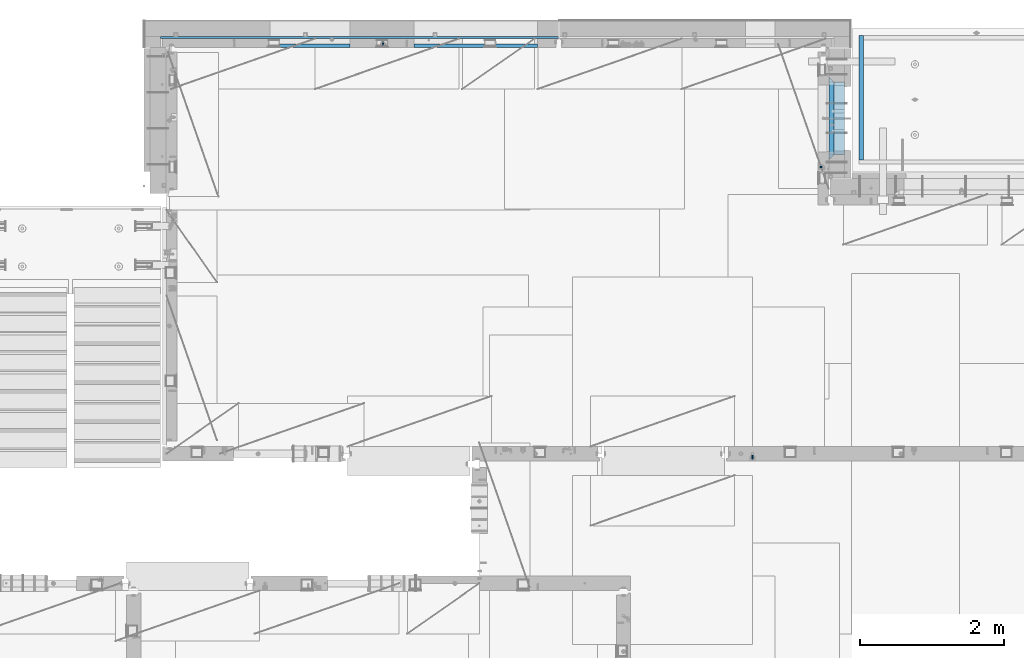
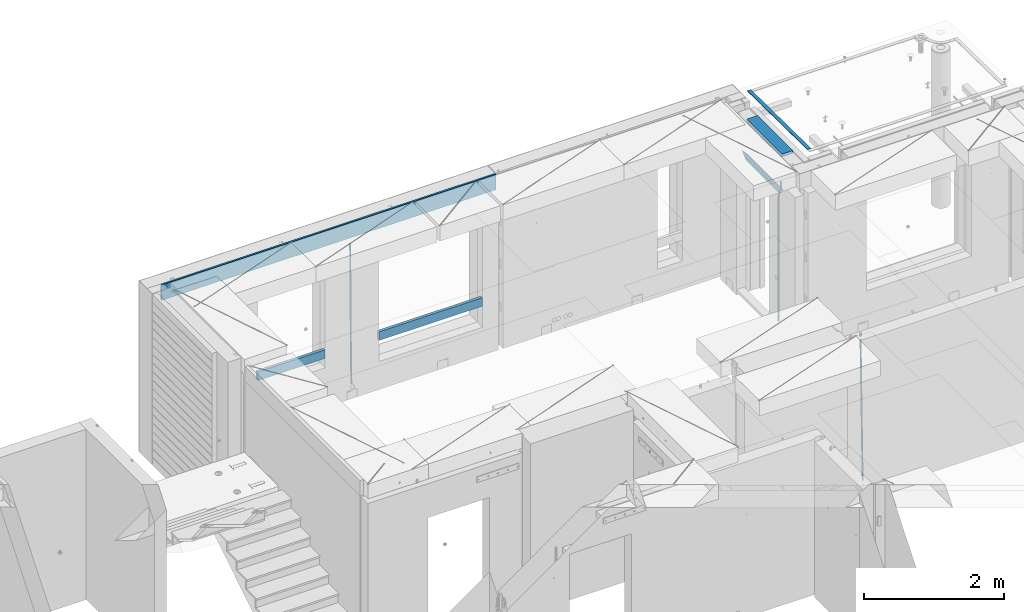
# One storey, part 120 of 334: 10 beams, 4 elements without a shape of their own.
"""IFC2X3 building model written with IfcOpenShell, lengths in millimetres."""

from ifc_helpers import new_model, si_unit, frame, origin_with_axes, place, context, subcontext, project, spatial, faceted_brep, material, type_object, element, aggregate, save


model = new_model("IFC2X3")

# Units and contexts
model_context = context("Model", 3, precision=1e-05, world=origin_with_axes())
body_context = subcontext(model_context, "Body", "Model", "MODEL_VIEW")
ifc_project = project(units=[si_unit("LENGTHUNIT", "METRE", prefix="MILLI"), si_unit("AREAUNIT", "SQUARE_METRE"), si_unit("VOLUMEUNIT", "CUBIC_METRE"), si_unit("MASSUNIT", "GRAM", prefix="KILO"), si_unit("TIMEUNIT", "SECOND"), si_unit("PLANEANGLEUNIT", "RADIAN"), si_unit("SOLIDANGLEUNIT", "STERADIAN"), si_unit("THERMODYNAMICTEMPERATUREUNIT", "DEGREE_CELSIUS"), si_unit("LUMINOUSINTENSITYUNIT", "LUMEN")], contexts=[model_context])

# Site, building, storey
site_placement = place(None, origin_with_axes())
site = spatial("IfcSite", under=ifc_project, at=site_placement, CompositionType="ELEMENT")
building_placement = place(site_placement, origin_with_axes())
building = spatial("IfcBuilding", under=site, at=building_placement, CompositionType="ELEMENT")
storey_placement = place(building_placement, origin_with_axes())
storey = spatial("IfcBuildingStorey", under=building, at=storey_placement, Name="3", CompositionType="ELEMENT", Elevation=0.0)

# Assembly, beams
assembly_1_placement = place(storey_placement, origin_with_axes())
assembly_1 = element("IfcElementAssembly", 1, at=assembly_1_placement, inside=storey, AssemblyPlace="NOTDEFINED", PredefinedType="REINFORCEMENT_UNIT")
ifc_material_1 = material(Name="CONCRETE/C25/30")
beam_type_1 = type_object("IfcBeamType", PredefinedType="NOTDEFINED")
beam_1_placement = place(assembly_1_placement, frame((31494.9951872276, 21060.0002716511, 90140.0), z_axis=(0.0, 0.0, -1.0), x_axis=(0.0, 1.0, 0.0)))
beam_1 = element("IfcBeam", 2, at=beam_1_placement, type_object=beam_type_1, material=ifc_material_1, Name="SK", context=body_context, shape_type="Brep", body=[
    faceted_brep([(70.0000000000164, -35.0, 35.0), (70.0000000000164, 35.0, 35.0), (0.0, -35.0, -35.0), (1079.99961853027, 35.0, 35.0), (1149.99961853027, -35.0, -35.0), (1079.99961853027, -35.0, 35.0)], [[[0, 1, 2]], [[2, 1, 3, 4]], [[0, 2, 4, 5]], [[1, 0, 5, 3]], [[4, 3, 5]]]),
])
beam_type_2 = type_object("IfcBeamType", PredefinedType="NOTDEFINED")
beam_2_placement = place(assembly_1_placement, frame((31494.9951872276, 21130.0002716511, 90080.0), z_axis=(0.0, 0.0, -1.0), x_axis=(0.0, 1.0, 0.0)))
beam_2 = element("IfcBeam", 3, at=beam_2_placement, type_object=beam_type_2, material=ifc_material_1, Name="SK", context=body_context, shape_type="Brep", body=[
    faceted_brep([(0.0, -35.0, -25.0), (43.8457723764295, -35.0, 18.8461538461561), (45.6406441713007, 35.0, 20.6410256410309), (0.0, 35.0, -25.0), (1009.99961853027, 35.0, -25.0), (1009.99961853027, -35.0, -25.0), (966.153464684117, -35.0, 18.8461538461561), (964.358592889246, 35.0, 20.6410256410309)], [[[0, 1, 2, 3]], [[0, 3, 4, 5]], [[1, 0, 5, 6]], [[6, 7, 2, 1]], [[3, 2, 7, 4]], [[6, 5, 4, 7]]]),
])

# Assembly, beam
assembly_2_placement = place(storey_placement, origin_with_axes())
assembly_2 = element("IfcElementAssembly", 4, at=assembly_2_placement, inside=storey, AssemblyPlace="NOTDEFINED", PredefinedType="REINFORCEMENT_UNIT")
ifc_material_2 = material()
beam_type_3 = type_object("IfcBeamType", Name="D20", PredefinedType="NOTDEFINED")
beam_3_placement = place(assembly_2_placement, frame((30400.0000000039, 16915.0002418615, 87990.0), z_axis=(-0.000205762999925498, 0.999642804629538, -0.0267249099901004), x_axis=(4.30000201928125e-08, 0.0267249099948059, 0.999642825806181)))
beam_3 = element("IfcBeam", 5, at=beam_3_placement, type_object=beam_type_3, material=ifc_material_2, Name="JM20", ObjectType="D20", context=body_context, shape_type="Brep", body=[
    faceted_brep([(0.0, -10.0, 0.0), (-4.19531716033816e-08, -7.07106781186667, -7.07106781187031), (60.4266690400545, -7.0710677960451, -7.07106780570757), (60.4266690441291, -9.99999998418934, 6.15546014159918e-09), (0.0, 0.0, -10.0), (60.426669036824, 1.58106558956206e-08, -9.99999999384454), (4.196772351861e-08, 7.07106781186303, -7.07106781186667), (60.4266690363438, 7.07106782768096, -7.07106780570757), (0.0, 10.0, 0.0), (60.4266690388904, 10.0000000158179, 6.15182216279209e-09), (4.196772351861e-08, 7.07106781185939, 7.07106781185939), (60.4266690429649, 7.07106782768096, 7.07106781802577), (0.0, 0.0, 10.0), (60.4266690461809, 1.58179318532348e-08, 10.0000000061555), (-4.19531716033816e-08, -7.07106781187031, 7.07106781185939), (60.4266690466611, -7.07106779605238, 7.07106781802213), (61.0378400410118, -7.07106779588503, -7.07106780564936), (60.991799419251, -9.99999998403655, 6.21366780251265e-09), (61.0569027789461, 1.5985278878361e-08, -9.99999999378269), (61.0378209396877, 7.07106782784831, -7.07106780564936), (60.9917724058905, 10.0000000159635, 6.21366780251265e-09), (60.9457317841297, 7.07106782781193, 7.0710678180767), (60.9266690461809, 1.59488990902901e-08, 10.0000000062028), (60.9457508854539, -7.07106779591413, 7.0710678180767), (61.6489592143771, -7.07106614513759, -7.06310863441468), (61.5568818710308, -9.9999984576425, 0.00735959856683621), (61.6870830769039, 1.71821739058942e-06, -9.99179257185824), (61.6489210170112, 7.07106947854481, -7.06310888312146), (61.556827851804, 10.0000015422847, 0.00735924683976918), (61.4647505084577, 7.07106922979438, 7.07782747982128), (61.4266266459163, 1.36643211590126e-06, 10.0065114172685), (61.464788705809, -7.07106639389531, 7.07782772852806), (176.543135720174, -7.07075579406956, -5.56673531796696), (176.451058376813, -9.99968810657447, 1.50373291501455), (176.581259582701, 0.000312069292704109, -8.49541925541052), (176.543097522794, 7.07137982961285, -5.56673556667374), (176.451004357587, 10.00031189336, 1.50373256329476), (176.35892701424, 7.07137958085514, 8.57420079627263), (176.320803151699, 0.000311717507429421, 11.5028847337162), (176.358965211621, -7.07075604281999, 8.57420104497578), (177.098753836006, -7.07075429323595, -5.55949898843028), (176.98362511232, -9.99968666800123, 1.510669025065), (177.146421932586, 0.000313595905026887, -8.48805862247536), (177.098706077581, 7.07138133041735, -5.55949936166144), (176.983557571715, 10.0003133318824, 1.51066849724157), (176.868428848029, 7.07138095712435, 8.58083651073321), (176.820760751449, 0.000313067976094317, 11.5093961447819), (176.868476606425, -7.07075466652896, 8.58083688396073), (177.654312950661, -7.07075204110879, -5.54863964998367), (177.516135294456, -9.99968450931192, 1.52107783331303), (177.711524267797, 0.000315886711177882, -8.47701274570863), (177.654255632195, 7.07138358250813, -5.54864021007961), (177.516054233929, 10.0003154905207, 1.5210770412159), (177.377876577739, 7.0713830223176, 8.59079452451624), (177.320665260588, 0.000315094497636892, 11.5191676202448), (177.377933896176, -7.07075260129932, 8.59079508461218), (299.499456785634, -7.07025810522464, -3.16697112782276), (299.361279129444, -9.99919057342777, 3.90274635547394), (299.556668102785, 0.000809822595329024, -6.09534422354773), (299.499399467197, 7.07187751838501, -3.1669716879187), (299.361198068917, 10.0008094264049, 3.90274556338045), (299.223020412712, 7.07187695819448, 10.9724630466735), (299.165809095575, 0.000809030381788034, 13.9008361423985), (299.223077731163, -7.07025866542244, 10.9724636067695), (300.03174732349, -7.07025594743027, -3.15656661289177), (299.971788958996, -9.99918809853989, 3.91467979818117), (300.056572611924, 0.000811849109595641, -6.08557274808481), (300.031722507032, 7.07187967631762, -3.15656653768019), (299.971753863239, 10.0008119014747, 3.91467990454839), (299.91179549876, 7.07187975035777, 10.9859263156177), (299.886970210311, 0.000811953817901667, 13.9149324508144), (299.911820315203, -7.0702558733974, 10.9859262404061), (300.564137759997, -7.07025623699155, -3.15794273276697), (300.582413367199, -9.99918843065097, 3.91310145956595), (300.556570941641, 0.000811577163403854, -6.0868651410201), (300.564145451674, 7.07187938674906, -3.15794274158179), (300.582424244858, 10.0008115693345, 3.91310144710224), (300.600699852032, 7.07187937566778, 10.9841456394352), (300.608266670402, 0.000811561512819026, 13.9130680476919), (300.600692160384, -7.07025624805829, 10.98414564825), (2294.16589219622, -7.0713405251372, -8.31099358700158), (2294.1841678034, -10.0002727187966, -1.23994939466866), (2294.15832537785, -0.000272710982244462, -11.2399159952547), (2294.16589988787, 7.07079509858886, -8.31099359582004), (2294.18417868105, 9.99972728118883, -1.23994940713601), (2294.20245428824, 7.07079508752213, 5.83109478519327), (2294.2100211066, -0.00027272663282929, 8.76001719345368), (2294.20244659658, -7.07134053620393, 5.83109479401173), (2294.7782683276, -7.07134085819416, -8.31257645345977), (2294.72126025338, -10.000273010919, -1.24133766827799), (2294.84007459224, -0.000273081772320438, -11.2416781768807), (2294.87047377572, 7.07079471537872, -8.31281477453012), (2294.85165844864, 9.9997269181622, -1.24167470516841), (2294.7946503744, 7.07079476544459, 5.82956408001337), (2294.73284410976, -0.000273010977252852, 8.75866580342336), (2294.7024449263, -7.07134080815013, 5.82980240107645), (2295.39054023061, -7.0793250091956, -8.30442771922026), (2295.25826128852, -10.0072756143927, -1.23419071494573), (2295.52170777075, -0.00916171800054144, -11.2326063125765), (2295.57492774284, 7.06160849139269, -8.30343918807193), (2295.51902460904, 9.99102432676591, -1.23279272078435), (2295.38674566693, 7.06307372157607, 5.83744428349019), (2295.25557812679, -0.0070895696117077, 8.76562287684646), (2295.20235815471, -7.07785977901949, 5.83645575234186), (2317.1947101649, -7.36365585014573, -8.01423575520312), (2317.06243122277, -10.2916064553428, -0.94399875092131), (2317.32587770502, -0.293492558957951, -10.9424143485521), (2317.37909767711, 6.77727765044983, -8.01324722405116), (2317.32319454331, 9.70669348581578, -0.942600756767206), (2317.1909156012, 6.77874288063322, 6.12763624751096), (2317.05974806109, -0.291420410569117, 9.0558148408636), (2317.00652808898, -7.36219061996962, 6.12664771636264), (2317.83015404257, -7.37194216843636, -8.00577862486898), (2317.72252095213, -10.300214160583, -0.935213608652703), (2317.90419832576, -0.301033978277701, -10.9347174723516), (2317.90127966482, 6.77046829039318, -8.00629749759901), (2317.82310777172, 9.70017451494641, -0.935947405505431), (2317.71547468127, 6.77190252279979, 6.13461761071085), (2317.64143039809, -0.29900566735887, 9.06355645819713), (2317.64434905903, -7.37050793602975, 6.13513648344451), (2318.46565174212, -7.3700661537805, -7.99751648408346), (2318.38266643914, -10.2982456018653, -0.926623872735945), (2318.48256818345, -0.299336209594912, -10.9272153854981), (2318.42350634121, 6.77200652527245, -7.99954269419686), (2318.32306384158, 9.70166538090416, -0.929489366557391), (2318.2400785386, 6.77348593281204, 6.14140324480104), (2318.22316209726, -0.297244011366274, 9.07110214621207), (2318.2822239395, -7.36858674623363, 6.1434294549108), (2418.48643733139, -7.07180401323421, -6.70013846199799), (2418.4034520284, -9.99998346132634, 0.370754149349523), (2418.5033537727, -0.00107406904135132, -9.62983736341266), (2418.44429193046, 7.07026866581873, -6.70216467211139), (2418.34384943081, 9.99992752145772, 0.367888655531715), (2418.26086412782, 7.0717480733656, 7.43878126688651), (2418.24394768651, 0.00101812917273492, 10.3684801682975), (2418.30300952874, -7.07032460568735, 7.44080747699627)], [[[0, 1, 2, 3]], [[1, 4, 5, 2]], [[4, 6, 7, 5]], [[6, 8, 9, 7]], [[8, 10, 11, 9]], [[10, 12, 13, 11]], [[12, 14, 15, 13]], [[14, 0, 3, 15]], [[14, 12, 10, 8, 6, 4, 1, 0]], [[3, 2, 16, 17]], [[2, 5, 18, 16]], [[5, 7, 19, 18]], [[7, 9, 20, 19]], [[9, 11, 21, 20]], [[11, 13, 22, 21]], [[13, 15, 23, 22]], [[15, 3, 17, 23]], [[17, 16, 24, 25]], [[16, 18, 26, 24]], [[18, 19, 27, 26]], [[19, 20, 28, 27]], [[20, 21, 29, 28]], [[21, 22, 30, 29]], [[22, 23, 31, 30]], [[23, 17, 25, 31]], [[25, 24, 32, 33]], [[24, 26, 34, 32]], [[26, 27, 35, 34]], [[27, 28, 36, 35]], [[28, 29, 37, 36]], [[29, 30, 38, 37]], [[30, 31, 39, 38]], [[31, 25, 33, 39]], [[33, 32, 40, 41]], [[32, 34, 42, 40]], [[34, 35, 43, 42]], [[35, 36, 44, 43]], [[36, 37, 45, 44]], [[37, 38, 46, 45]], [[38, 39, 47, 46]], [[39, 33, 41, 47]], [[41, 40, 48, 49]], [[40, 42, 50, 48]], [[42, 43, 51, 50]], [[43, 44, 52, 51]], [[44, 45, 53, 52]], [[45, 46, 54, 53]], [[46, 47, 55, 54]], [[47, 41, 49, 55]], [[49, 48, 56, 57]], [[48, 50, 58, 56]], [[50, 51, 59, 58]], [[51, 52, 60, 59]], [[52, 53, 61, 60]], [[53, 54, 62, 61]], [[54, 55, 63, 62]], [[55, 49, 57, 63]], [[57, 56, 64, 65]], [[56, 58, 66, 64]], [[58, 59, 67, 66]], [[59, 60, 68, 67]], [[60, 61, 69, 68]], [[61, 62, 70, 69]], [[62, 63, 71, 70]], [[63, 57, 65, 71]], [[65, 64, 72, 73]], [[64, 66, 74, 72]], [[66, 67, 75, 74]], [[67, 68, 76, 75]], [[68, 69, 77, 76]], [[69, 70, 78, 77]], [[70, 71, 79, 78]], [[71, 65, 73, 79]], [[73, 72, 80, 81]], [[72, 74, 82, 80]], [[74, 75, 83, 82]], [[75, 76, 84, 83]], [[76, 77, 85, 84]], [[77, 78, 86, 85]], [[78, 79, 87, 86]], [[79, 73, 81, 87]], [[81, 80, 88, 89]], [[80, 82, 90, 88]], [[82, 83, 91, 90]], [[83, 84, 92, 91]], [[84, 85, 93, 92]], [[85, 86, 94, 93]], [[86, 87, 95, 94]], [[87, 81, 89, 95]], [[89, 88, 96, 97]], [[88, 90, 98, 96]], [[90, 91, 99, 98]], [[91, 92, 100, 99]], [[92, 93, 101, 100]], [[93, 94, 102, 101]], [[94, 95, 103, 102]], [[95, 89, 97, 103]], [[97, 96, 104, 105]], [[96, 98, 106, 104]], [[98, 99, 107, 106]], [[99, 100, 108, 107]], [[100, 101, 109, 108]], [[101, 102, 110, 109]], [[102, 103, 111, 110]], [[103, 97, 105, 111]], [[105, 104, 112, 113]], [[104, 106, 114, 112]], [[106, 107, 115, 114]], [[107, 108, 116, 115]], [[108, 109, 117, 116]], [[109, 110, 118, 117]], [[110, 111, 119, 118]], [[111, 105, 113, 119]], [[113, 112, 120, 121]], [[112, 114, 122, 120]], [[114, 115, 123, 122]], [[115, 116, 124, 123]], [[116, 117, 125, 124]], [[117, 118, 126, 125]], [[118, 119, 127, 126]], [[119, 113, 121, 127]], [[121, 120, 128, 129]], [[120, 122, 130, 128]], [[122, 123, 131, 130]], [[123, 124, 132, 131]], [[124, 125, 133, 132]], [[125, 126, 134, 133]], [[126, 127, 135, 134]], [[127, 121, 129, 135]], [[130, 131, 132, 133, 134, 135, 129, 128]]]),
])
aggregate(assembly_2, [beam_3])

# Beam
beam_4_placement = place(assembly_1_placement, frame((31384.9951872298, 20959.9999999916, 90407.5), z_axis=(-0.999999913638316, 0.000415599999849952, 0.0), x_axis=(0.0, 0.0, -1.0)))
beam_4 = element("IfcBeam", 6, at=beam_4_placement, type_object=beam_type_3, material=ifc_material_2, Name="JM20", ObjectType="D20", context=body_context, shape_type="Brep", body=[
    faceted_brep([(0.0, -10.0, 0.0), (-4.19531716033816e-08, -7.07106781186667, -7.07106781187031), (113.248091332178, -7.0710684840451, -7.0710678117357), (113.248091314759, -10.0000006713562, -2.51020537689328e-10), (0.0, 0.0, -10.0), (113.248091374131, -6.72178430249915e-07, -9.99999999986903), (4.196772351861e-08, 7.07106781186303, -7.07106781186667), (113.248091416113, 7.07106713968824, -7.07106781173934), (0.0, 10.0, 0.0), (113.248091433488, 9.99999932782521, 1.30967237055302e-10), (4.196772351861e-08, 7.07106781185939, 7.07106781185939), (113.248091416113, 7.0710671396846, 7.071067811994), (0.0, 0.0, 10.0), (113.248091374131, -6.72174792271107e-07, 10.0000000001273), (-4.19531716033816e-08, -7.07106781187031, 7.07106781185939), (113.248091332178, -7.0710684840451, 7.071067811994), (130.699843527167, -7.06993249763036, -4.33745683788584), (128.538066582521, -9.99900540317321, 2.39499413731755), (131.594536475241, 0.00119355250353692, -7.12624594330919), (130.698046432328, 7.07220300913468, -4.33773834422391), (128.535525107087, 10.0009944322555, 2.39459602660281), (126.373748162892, 7.07192152754578, 9.1270470011732), (125.479055214906, 0.000795477419160306, 11.9158361066184), (126.37554525779, -7.07021397921199, 9.12732850753673), (240.336258550378, -7.05529970173666, 30.8729495437874), (238.174481606227, -9.98437260450009, 37.6054005176375), (241.230951498423, 0.0158263482953771, 28.0841604381058), (240.334461455612, 7.0868358050102, 30.8726680369582), (238.171940130502, 10.0156272283348, 37.6050024077231), (236.010163186409, 7.08655432384694, 44.3374533824244), (235.115470238379, 0.0154282738185429, 47.1262424881097), (236.011960281176, -7.05558118289991, 44.3377348892536), (253.461915329972, -7.05444528127919, 32.9289287376414), (253.46191532613, -9.98337746617108, 39.9999965521893), (253.461915339081, 0.0166225284556276, 29.9999965443676), (253.461915348205, 7.08769034247234, 32.9289287273205), (253.461915352003, 10.0166225357716, 39.9999965370152), (253.461915348293, 7.08769035281148, 47.0710643509774), (253.461915339183, 0.0166225430875784, 49.999996544273), (253.46191533003, -7.05444527093641, 47.0710643613093), (2417.50000002384, -7.0544364694706, 32.9289287374122), (2417.5000000337, -9.98336865393321, 39.9999965507959), (2417.49999999997, 0.0166313408753922, 29.9999965456082), (2417.49999997609, 7.08769915426274, 32.9289287300708), (2417.4999999662, 10.0166313460668, 39.9999965404204), (2417.49999997608, 7.08769916160054, 47.0710643538114), (2417.49999999994, 0.0166313512581837, 49.9999965456154), (2417.50000002382, -7.05443646212916, 47.0710643611455)], [[[0, 1, 2, 3]], [[1, 4, 5, 2]], [[4, 6, 7, 5]], [[6, 8, 9, 7]], [[8, 10, 11, 9]], [[10, 12, 13, 11]], [[12, 14, 15, 13]], [[14, 0, 3, 15]], [[14, 12, 10, 8, 6, 4, 1, 0]], [[3, 2, 16, 17]], [[2, 5, 18, 16]], [[5, 7, 19, 18]], [[7, 9, 20, 19]], [[9, 11, 21, 20]], [[11, 13, 22, 21]], [[13, 15, 23, 22]], [[15, 3, 17, 23]], [[17, 16, 24, 25]], [[16, 18, 26, 24]], [[18, 19, 27, 26]], [[19, 20, 28, 27]], [[20, 21, 29, 28]], [[21, 22, 30, 29]], [[22, 23, 31, 30]], [[23, 17, 25, 31]], [[25, 24, 32, 33]], [[24, 26, 34, 32]], [[26, 27, 35, 34]], [[27, 28, 36, 35]], [[28, 29, 37, 36]], [[29, 30, 38, 37]], [[30, 31, 39, 38]], [[31, 25, 33, 39]], [[33, 32, 40, 41]], [[32, 34, 42, 40]], [[34, 35, 43, 42]], [[35, 36, 44, 43]], [[36, 37, 45, 44]], [[37, 38, 46, 45]], [[38, 39, 47, 46]], [[39, 33, 41, 47]], [[42, 43, 44, 45, 46, 47, 41, 40]]]),
])

# Assembly, beams
assembly_3_placement = place(storey_placement, origin_with_axes())
assembly_3 = element("IfcElementAssembly", 7, at=assembly_3_placement, inside=storey, AssemblyPlace="NOTDEFINED", PredefinedType="REINFORCEMENT_UNIT")
beam_5_placement = place(assembly_3_placement, frame((25270.0000000039, 22654.999995444, 87990.0), z_axis=(-0.000205762999925498, 0.999642804629538, -0.0267249099901004), x_axis=(4.30000201928125e-08, 0.0267249099948059, 0.999642825806181)))
beam_5 = element("IfcBeam", 8, at=beam_5_placement, type_object=beam_type_3, material=ifc_material_2, Name="JM20", ObjectType="D20", context=body_context, shape_type="Brep", body=[
    faceted_brep([(0.0, -10.0, 0.0), (-4.19531716033816e-08, -7.07106781186667, -7.07106781187031), (60.4266690400545, -7.0710677960451, -7.07106780570757), (60.4266690441291, -9.99999998418934, 6.15546014159918e-09), (0.0, 0.0, -10.0), (60.426669036824, 1.58106558956206e-08, -9.99999999384454), (4.196772351861e-08, 7.07106781186303, -7.07106781186667), (60.4266690363438, 7.07106782768096, -7.07106780570757), (0.0, 10.0, 0.0), (60.4266690388904, 10.0000000158179, 6.15182216279209e-09), (4.196772351861e-08, 7.07106781185939, 7.07106781185939), (60.4266690429649, 7.07106782768096, 7.07106781802577), (0.0, 0.0, 10.0), (60.4266690461809, 1.58179318532348e-08, 10.0000000061555), (-4.19531716033816e-08, -7.07106781187031, 7.07106781185939), (60.4266690466611, -7.07106779605238, 7.07106781802213), (61.0378400410118, -7.07106779588503, -7.07106780564936), (60.991799419251, -9.99999998403655, 6.21366780251265e-09), (61.0569027789461, 1.5985278878361e-08, -9.99999999378269), (61.0378209396877, 7.07106782784831, -7.07106780564936), (60.9917724058905, 10.0000000159635, 6.21366780251265e-09), (60.9457317841297, 7.07106782781193, 7.0710678180767), (60.9266690461809, 1.59488990902901e-08, 10.0000000062028), (60.9457508854539, -7.07106779591413, 7.0710678180767), (61.6489592143771, -7.07106614513759, -7.06310863441468), (61.5568818710308, -9.9999984576425, 0.00735959856683621), (61.6870830769039, 1.71821739058942e-06, -9.99179257185824), (61.6489210170112, 7.07106947854481, -7.06310888312146), (61.556827851804, 10.0000015422847, 0.00735924683976918), (61.4647505084577, 7.07106922979438, 7.07782747982128), (61.4266266459163, 1.36643211590126e-06, 10.0065114172685), (61.464788705809, -7.07106639389531, 7.07782772852806), (176.543135720174, -7.07075579406956, -5.56673531796696), (176.451058376813, -9.99968810657447, 1.50373291501455), (176.581259582701, 0.000312069292704109, -8.49541925541052), (176.543097522794, 7.07137982961285, -5.56673556667374), (176.451004357587, 10.00031189336, 1.50373256329476), (176.35892701424, 7.07137958085514, 8.57420079627263), (176.320803151699, 0.000311717507429421, 11.5028847337162), (176.358965211621, -7.07075604281999, 8.57420104497578), (177.098753836006, -7.07075429323595, -5.55949898843028), (176.98362511232, -9.99968666800123, 1.510669025065), (177.146421932586, 0.000313595905026887, -8.48805862247536), (177.098706077581, 7.07138133041735, -5.55949936166144), (176.983557571715, 10.0003133318824, 1.51066849724157), (176.868428848029, 7.07138095712435, 8.58083651073321), (176.820760751449, 0.000313067976094317, 11.5093961447819), (176.868476606425, -7.07075466652896, 8.58083688396073), (177.654312950661, -7.07075204110879, -5.54863964998367), (177.516135294456, -9.99968450931192, 1.52107783331303), (177.711524267797, 0.000315886711177882, -8.47701274570863), (177.654255632195, 7.07138358250813, -5.54864021007961), (177.516054233929, 10.0003154905207, 1.5210770412159), (177.377876577739, 7.0713830223176, 8.59079452451624), (177.320665260588, 0.000315094497636892, 11.5191676202448), (177.377933896176, -7.07075260129932, 8.59079508461218), (299.436796249574, -7.07025836271714, -3.1681962331204), (299.298618593355, -9.99919083092027, 3.90152125031091), (299.494007566798, 0.000809565110102994, -6.09656932889993), (299.436738931283, 7.07187726089978, -3.16819679320906), (299.298537533061, 10.0008091689197, 3.90152045822106), (299.160359876842, 7.07187670072017, 10.9712379416487), (299.103148559603, 0.000808772889286047, 13.8996110374392), (299.160417195119, -7.07025892290039, 10.9712385017483), (299.98743051647, -7.07025613056248, -3.15743315966392), (299.971788958996, -9.99918809853989, 3.91467979818117), (299.993912075952, 0.000811591617093654, -6.08679785393178), (299.987423933868, 7.07187949325817, -3.1574327280432), (299.971753863239, 10.0008119014747, 3.91467990454839), (299.95611230444, 7.07187992653053, 10.9867922621015), (299.949630744944, 0.000812204350950196, 13.9161569563694), (299.956118887014, -7.07025569729012, 10.9867918304735), (300.538107039494, -7.07025785017686, -3.16575821840888), (300.644985195438, -9.99919020432935, 3.90450175465594), (300.493854948218, 0.000810030429420294, -6.09435592770024), (300.538151196495, 7.071877773491, -3.16575855385963), (300.645047642858, 10.0008097955724, 3.90450128024895), (300.751925798773, 7.07187744142357, 10.9747612533101), (300.796177890064, 0.000809560813650023, 13.9033589625978), (300.751881641787, -7.07025818224065, 10.9747615887682), (2293.36490490142, -7.07648090940347, -33.2930642912361), (2293.47178305736, -10.0054132635523, -26.2228043181785), (2293.32065281013, -0.00541302880083094, -36.2216620005347), (2293.36494905842, 7.06565471425711, -33.2930646266868), (2293.47184550477, 9.99458673634581, -26.2228047925819), (2293.57872366071, 7.06565438219332, -19.1525448195243), (2293.62297575199, -0.00541349841296324, -16.2239471102366), (2293.57867950371, -7.0764812414709, -19.1525444840736), (2294.0658245362, -7.07648309818615, -33.3036607065333), (2294.05312277409, -10.0054150789219, -26.2315929392535), (2294.10928714235, -0.00541549149056664, -36.2335844756526), (2294.15805078732, 7.06565223761572, -33.3050546393533), (2294.18355038921, 9.99458451388637, -26.2335642579346), (2294.17084862708, 7.06565253314329, -19.1614964906439), (2294.12738602093, -0.00541507354500936, -16.2315727215355), (2294.07862237596, -7.07648280265857, -19.1601025578348), (2294.76670261032, -7.08562269121467, -33.294332712383), (2294.63442802057, -10.0129954178956, -26.2238563411993), (2294.89787471293, -0.0156988342423574, -36.2230891548279), (2294.95110548967, 7.05531064255774, -33.2944998654275), (2294.89521307347, 9.98530428734011, -26.2240927312887), (2294.76293848372, 7.0579315606592, -19.1536163601049), (2294.63176638114, -0.0119922963167483, -16.2248599176673), (2294.57853560438, -7.08300177311321, -19.1534492070678), (2316.52657204497, -7.36937582653991, -33.0047303660212), (2316.39429745522, -10.2967485532172, -25.9342539948302), (2316.65774414754, -0.299451969567599, -35.9334868084661), (2316.7109749243, 6.7715575072325, -33.0048975190657), (2316.65508250811, 9.70155115201487, -25.9344903849269), (2316.52280791836, 6.7741784253376, -18.8640140137468), (2316.39163581574, -0.295745431634714, -15.9352575713092), (2316.33840503903, -7.36675490843481, -18.863846860706), (2317.16202064224, -7.37766220584308, -32.9962731735213), (2317.05438744847, -10.3053562613532, -25.9254688497131), (2317.23607125619, -0.306993473008333, -35.925789846493), (2317.23316144495, 6.76474808850253, -32.9979477328052), (2317.15499573652, 9.6950321815566, -25.9278370341635), (2317.04736254275, 6.7673381260538, -18.8570327103698), (2316.97331192881, -0.303330606784584, -15.9275160373909), (2316.97622174003, -7.37507216829545, -18.8553581510787), (2317.79752306276, -7.37578610372293, -32.9880110666527), (2317.71453320107, -10.3033876998124, -25.9168792378296), (2317.81444760226, -0.305295583297266, -35.918287695793), (2317.75539265381, 6.76628640723357, -32.9911928173897), (2317.65495180529, 9.69652304524061, -25.9213789128698), (2317.5719619436, 6.76892144914746, -18.8502470840467), (2317.55503740412, -0.301569071270933, -15.9199704549137), (2317.61409235255, -7.3731510618054, -18.847065333317), (2417.8183084176, -7.07752398473531, -31.6906369377139), (2417.73531855589, -10.0051255808248, -24.6195051088798), (2417.83523295709, -0.007033464313281, -34.6209135668432), (2417.77617800863, 7.06454852621755, -31.6938186884508), (2417.67573716014, 9.99478516423187, -24.6240047839383), (2417.59274729842, 7.06718356813872, -17.5528729551006), (2417.57582275895, -0.00330695228694822, -14.6225963259749), (2417.6348777074, -7.07488894281778, -17.5496912043673)], [[[0, 1, 2, 3]], [[1, 4, 5, 2]], [[4, 6, 7, 5]], [[6, 8, 9, 7]], [[8, 10, 11, 9]], [[10, 12, 13, 11]], [[12, 14, 15, 13]], [[14, 0, 3, 15]], [[14, 12, 10, 8, 6, 4, 1, 0]], [[3, 2, 16, 17]], [[2, 5, 18, 16]], [[5, 7, 19, 18]], [[7, 9, 20, 19]], [[9, 11, 21, 20]], [[11, 13, 22, 21]], [[13, 15, 23, 22]], [[15, 3, 17, 23]], [[17, 16, 24, 25]], [[16, 18, 26, 24]], [[18, 19, 27, 26]], [[19, 20, 28, 27]], [[20, 21, 29, 28]], [[21, 22, 30, 29]], [[22, 23, 31, 30]], [[23, 17, 25, 31]], [[25, 24, 32, 33]], [[24, 26, 34, 32]], [[26, 27, 35, 34]], [[27, 28, 36, 35]], [[28, 29, 37, 36]], [[29, 30, 38, 37]], [[30, 31, 39, 38]], [[31, 25, 33, 39]], [[33, 32, 40, 41]], [[32, 34, 42, 40]], [[34, 35, 43, 42]], [[35, 36, 44, 43]], [[36, 37, 45, 44]], [[37, 38, 46, 45]], [[38, 39, 47, 46]], [[39, 33, 41, 47]], [[41, 40, 48, 49]], [[40, 42, 50, 48]], [[42, 43, 51, 50]], [[43, 44, 52, 51]], [[44, 45, 53, 52]], [[45, 46, 54, 53]], [[46, 47, 55, 54]], [[47, 41, 49, 55]], [[49, 48, 56, 57]], [[48, 50, 58, 56]], [[50, 51, 59, 58]], [[51, 52, 60, 59]], [[52, 53, 61, 60]], [[53, 54, 62, 61]], [[54, 55, 63, 62]], [[55, 49, 57, 63]], [[57, 56, 64, 65]], [[56, 58, 66, 64]], [[58, 59, 67, 66]], [[59, 60, 68, 67]], [[60, 61, 69, 68]], [[61, 62, 70, 69]], [[62, 63, 71, 70]], [[63, 57, 65, 71]], [[65, 64, 72, 73]], [[64, 66, 74, 72]], [[66, 67, 75, 74]], [[67, 68, 76, 75]], [[68, 69, 77, 76]], [[69, 70, 78, 77]], [[70, 71, 79, 78]], [[71, 65, 73, 79]], [[73, 72, 80, 81]], [[72, 74, 82, 80]], [[74, 75, 83, 82]], [[75, 76, 84, 83]], [[76, 77, 85, 84]], [[77, 78, 86, 85]], [[78, 79, 87, 86]], [[79, 73, 81, 87]], [[81, 80, 88, 89]], [[80, 82, 90, 88]], [[82, 83, 91, 90]], [[83, 84, 92, 91]], [[84, 85, 93, 92]], [[85, 86, 94, 93]], [[86, 87, 95, 94]], [[87, 81, 89, 95]], [[89, 88, 96, 97]], [[88, 90, 98, 96]], [[90, 91, 99, 98]], [[91, 92, 100, 99]], [[92, 93, 101, 100]], [[93, 94, 102, 101]], [[94, 95, 103, 102]], [[95, 89, 97, 103]], [[97, 96, 104, 105]], [[96, 98, 106, 104]], [[98, 99, 107, 106]], [[99, 100, 108, 107]], [[100, 101, 109, 108]], [[101, 102, 110, 109]], [[102, 103, 111, 110]], [[103, 97, 105, 111]], [[105, 104, 112, 113]], [[104, 106, 114, 112]], [[106, 107, 115, 114]], [[107, 108, 116, 115]], [[108, 109, 117, 116]], [[109, 110, 118, 117]], [[110, 111, 119, 118]], [[111, 105, 113, 119]], [[113, 112, 120, 121]], [[112, 114, 122, 120]], [[114, 115, 123, 122]], [[115, 116, 124, 123]], [[116, 117, 125, 124]], [[117, 118, 126, 125]], [[118, 119, 127, 126]], [[119, 113, 121, 127]], [[121, 120, 128, 129]], [[120, 122, 130, 128]], [[122, 123, 131, 130]], [[123, 124, 132, 131]], [[124, 125, 133, 132]], [[125, 126, 134, 133]], [[126, 127, 135, 134]], [[127, 121, 129, 135]], [[130, 131, 132, 133, 134, 135, 129, 128]]]),
])
ifc_material_3 = material(Name="TIMBER/T24")
beam_type_4 = type_object("IfcBeamType", PredefinedType="NOTDEFINED")
beam_6_placement = place(assembly_3_placement, frame((27415.0002980493, 22644.9998418812, 88685.0), z_axis=(0.0, 0.0, 1.0), x_axis=(-1.0, 3.00000001838171e-08, 0.0)))
beam_6 = element("IfcBeam", 9, at=beam_6_placement, type_object=beam_type_4, material=ifc_material_3, context=body_context, shape_type="Brep", body=[
    faceted_brep([(-3.63797880709171e-12, 24.9999999999964, -75.0), (-3.63797880709171e-12, 24.9999999999964, 75.0), (1710.0, 25.0, 75.0), (1710.0, 25.0, -75.0), (0.0, -25.0000000000073, 75.0), (1709.99999999999, -25.0, 75.0), (0.0, -25.0000000000073, -75.0), (1709.99999999999, -25.0, -75.0)], [[[0, 1, 2, 3]], [[1, 4, 5, 2]], [[4, 6, 7, 5]], [[6, 0, 3, 7]], [[5, 7, 3, 2]], [[6, 4, 1, 0]]]),
])
beam_7_placement = place(assembly_3_placement, frame((24815.0002989914, 22644.9998418812, 88685.0), z_axis=(0.0, 0.0, 1.0), x_axis=(-1.0, 3.00000001838171e-08, 0.0)))
beam_7 = element("IfcBeam", 10, at=beam_7_placement, type_object=beam_type_4, material=ifc_material_3, context=body_context, shape_type="Brep", body=[
    faceted_brep([(-3.63797880709171e-12, 24.9999999999964, -75.0), (-3.63797880709171e-12, 24.9999999999964, 75.0), (1110.0, 24.9999999999964, 75.0), (1110.0, 24.9999999999964, -75.0), (0.0, -25.0000000000073, 75.0), (1110.0, -25.0000000000073, 75.0), (0.0, -25.0000000000073, -75.0), (1110.0, -25.0000000000073, -75.0)], [[[0, 1, 2, 3]], [[1, 4, 5, 2]], [[4, 6, 7, 5]], [[6, 0, 3, 7]], [[5, 7, 3, 2]], [[6, 4, 1, 0]]]),
])

# Assembly, beam
assembly_4_placement = place(storey_placement, origin_with_axes())
assembly_4 = element("IfcElementAssembly", 11, at=assembly_4_placement, inside=storey, AssemblyPlace="NOTDEFINED", PredefinedType="REINFORCEMENT_UNIT")
ifc_material_4 = material(Name="CONCRETE/Concrete_Undefined")
beam_type_5 = type_object("IfcBeamType", PredefinedType="NOTDEFINED")
beam_8_placement = place(assembly_4_placement, frame((31909.9986098709, 21060.0524822207, 90725.2791116282), z_axis=(7.99999906921644e-09, 0.0107912409985276, 0.999941772863656), x_axis=(7.22999999800065e-07, 0.999941772863395, -0.0107912409985247)))
beam_8 = element("IfcBeam", 12, at=beam_8_placement, type_object=beam_type_5, material=ifc_material_4, context=body_context, shape_type="Brep", body=[
    faceted_brep([(2.5465851649642e-11, 29.9999999999982, -4.99999999998545), (-2.91038304567337e-11, 29.9999999999982, 5.0), (1725.04446838825, 29.9999999999927, 4.99999999998545), (1725.04446838825, 29.9999999999927, -5.00000000001455), (-2.5465851649642e-11, -30.0000000000018, 5.0), (1725.04446838824, -30.0000000000073, 4.99999999998545), (2.72848410531878e-11, -30.0000000000018, -4.99999999998545), (1725.04446838824, -30.0000000000073, -5.0)], [[[0, 1, 2, 3]], [[1, 4, 5, 2]], [[4, 6, 7, 5]], [[6, 0, 3, 7]], [[5, 7, 3, 2]], [[6, 4, 1, 0]]]),
])
aggregate(assembly_4, [beam_8])

# Beam
beam_type_6 = type_object("IfcBeamType", Name="270X30", PredefinedType="NOTDEFINED")
beam_9_placement = place(assembly_3_placement, frame((27705.0, 22755.0, 90605.0), z_axis=(0.0, 0.0, 1.0), x_axis=(-1.0, 3.00000001838171e-08, 0.0)))
beam_9 = element("IfcBeam", 13, at=beam_9_placement, type_object=beam_type_6, material=ifc_material_1, ObjectType="270X30", context=body_context, shape_type="Brep", body=[
    faceted_brep([(0.0, 15.0, -135.0), (0.0, 15.0, 135.0), (5520.00000000003, 15.0, 135.0), (5520.00000000003, 15.0, -135.0), (0.0, -15.0, 135.0), (5520.00000000003, -15.0, 135.0), (0.0, -15.0, -135.0), (5520.00000000003, -15.0, -135.0)], [[[0, 1, 2, 3]], [[1, 4, 5, 2]], [[4, 6, 7, 5]], [[6, 0, 3, 7]], [[5, 7, 3, 2]], [[6, 4, 1, 0]]]),
])

aggregate(assembly_3, [beam_5, beam_9, beam_6, beam_7])

ifc_material_5 = material(Name="TIMBER")
beam_type_7 = type_object("IfcBeamType", PredefinedType="NOTDEFINED")
beam_10_placement = place(assembly_1_placement, frame((31589.9951872276, 22140.0000381475, 90715.0), z_axis=(0.0, 0.0, 1.0), x_axis=(0.0, -1.0, 0.0)))
beam_10 = element("IfcBeam", 14, at=beam_10_placement, type_object=beam_type_7, material=ifc_material_5, context=body_context, shape_type="Brep", body=[
    faceted_brep([(0.0, 90.0, -25.0), (0.0, 90.0, 25.0), (1009.99983857082, 90.0, 25.0), (1009.99983857082, 90.0, -25.0), (0.0, -90.0, 25.0), (1009.99983857082, -90.0, 25.0), (0.0, -90.0, -25.0), (1009.99983857082, -90.0, -25.0)], [[[0, 1, 2, 3]], [[1, 4, 5, 2]], [[4, 6, 7, 5]], [[6, 0, 3, 7]], [[5, 7, 3, 2]], [[6, 4, 1, 0]]]),
])

aggregate(assembly_1, [beam_4, beam_10, beam_1, beam_2])

save(model, "model.ifc")
